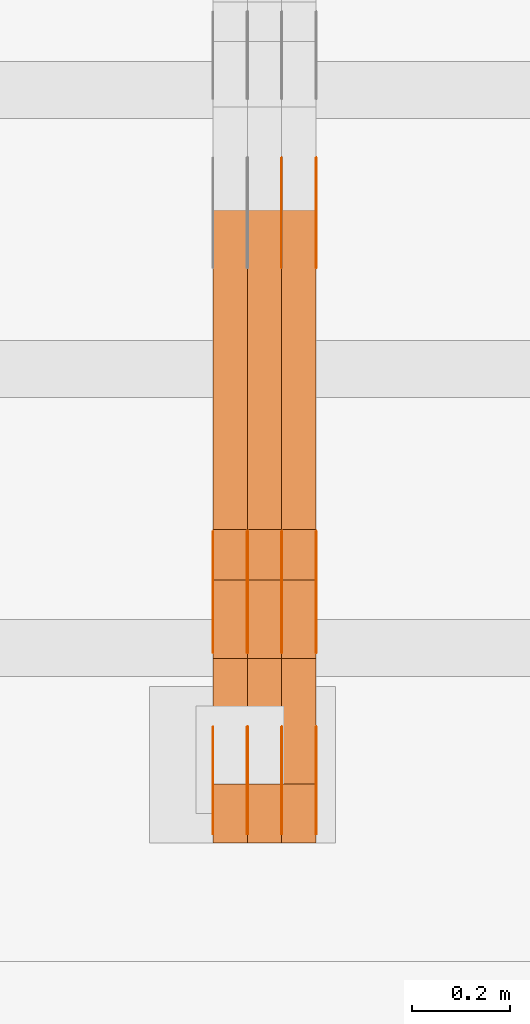
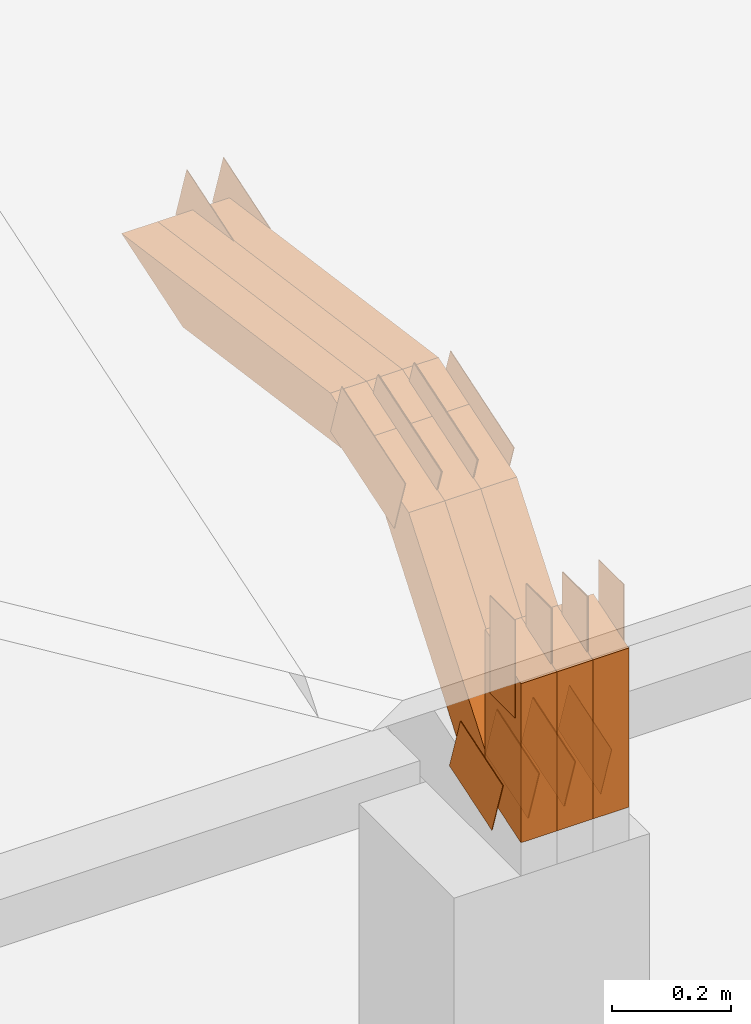
# One storey, part 108 of 385: 29 proxies.
"""IFC2X3 building model written with IfcOpenShell, lengths in millimetres."""

from ifc_helpers import new_model, entity, si_unit, converted_unit, derived_unit, direction, frame, frame_2d, origin, place, context, subcontext, project, spatial, polyline, rectangle, outline, extrude, source, transform, mapped, material, type_object, type_shapes, element, save


model = new_model("IFC2X3")

# Units and contexts
model_context = context("Model", 3, precision=0.01, world=origin(), true_north=direction((6.12303176911189e-17, 1.0)))
body_context = subcontext(model_context, "Body", "Model", "MODEL_VIEW")
ifc_project = project(units=[si_unit("LENGTHUNIT", "METRE", prefix="MILLI"), si_unit("AREAUNIT", "SQUARE_METRE"), si_unit("VOLUMEUNIT", "CUBIC_METRE"), converted_unit("PLANEANGLEUNIT", "DEGREE", entity("IfcRatioMeasure", 0.0174532925199433), si_unit("PLANEANGLEUNIT", "RADIAN"), dimensions=[0, 0, 0, 0, 0, 0, 0]), si_unit("MASSUNIT", "GRAM", prefix="KILO"), derived_unit("MASSDENSITYUNIT", [(si_unit("MASSUNIT", "GRAM", prefix="KILO"), 1), (si_unit("LENGTHUNIT", "METRE"), -3)]), si_unit("TIMEUNIT", "SECOND"), si_unit("FREQUENCYUNIT", "HERTZ"), si_unit("THERMODYNAMICTEMPERATUREUNIT", "DEGREE_CELSIUS"), derived_unit("THERMALTRANSMITTANCEUNIT", [(si_unit("MASSUNIT", "GRAM", prefix="KILO"), 1), (si_unit("THERMODYNAMICTEMPERATUREUNIT", "KELVIN"), -1), (si_unit("TIMEUNIT", "SECOND"), -3)]), derived_unit("VOLUMETRICFLOWRATEUNIT", [(si_unit("LENGTHUNIT", "METRE"), 3), (si_unit("TIMEUNIT", "SECOND"), -1)]), si_unit("ELECTRICCURRENTUNIT", "AMPERE"), si_unit("ELECTRICVOLTAGEUNIT", "VOLT"), si_unit("POWERUNIT", "WATT"), si_unit("FORCEUNIT", "NEWTON", prefix="KILO"), si_unit("ILLUMINANCEUNIT", "LUX"), si_unit("LUMINOUSFLUXUNIT", "LUMEN"), si_unit("LUMINOUSINTENSITYUNIT", "CANDELA"), derived_unit("USERDEFINED", [(si_unit("MASSUNIT", "GRAM", prefix="KILO"), -1), (si_unit("LENGTHUNIT", "METRE"), -2), (si_unit("TIMEUNIT", "SECOND"), 3), (si_unit("LUMINOUSFLUXUNIT", "LUMEN"), 1)]), derived_unit("LINEARVELOCITYUNIT", [(si_unit("LENGTHUNIT", "METRE"), 1), (si_unit("TIMEUNIT", "SECOND"), -1)]), si_unit("PRESSUREUNIT", "PASCAL"), derived_unit("USERDEFINED", [(si_unit("LENGTHUNIT", "METRE"), -2), (si_unit("MASSUNIT", "GRAM", prefix="KILO"), 1), (si_unit("TIMEUNIT", "SECOND"), -2)])], contexts=[model_context])

# Site, building, storey
site_placement = place(None, origin())
site = spatial("IfcSite", under=ifc_project, at=site_placement, CompositionType="ELEMENT")
building_placement = place(site_placement, origin())
building = spatial("IfcBuilding", under=site, at=building_placement, CompositionType="ELEMENT")
storey_placement = place(building_placement, origin())
storey = spatial("IfcBuildingStorey", under=building, at=storey_placement, Name="Default", CompositionType="ELEMENT", Elevation=0.0)

# Proxies
ifc_material_1 = material(Name="IfcSurfaceStyle #236732")
building_element_proxy_type_1 = type_object("IfcBuildingElementProxyType", PredefinedType="NOTDEFINED", material=ifc_material_1)
shared_shape_1 = source(origin(), body_context, "Body", "SweptSolid", [
    extrude(outline(polyline([(-74.999865408764, -60.0000379172698), (74.9998729365771, -60.0000379172698), (74.9998642299588, 60.0000379172698), (-74.9998717577719, 60.0000379172698), (-74.999865408764, -60.0000379172698)])), frame((75.0005044383734, 60.0001679035349, 0.0), z_axis=(0.0, 0.0, 1.0), x_axis=(-1.0, 0.0, 0.0)), (0.0, 0.0, 1.0), 1.3),
])
type_shapes(building_element_proxy_type_1, [shared_shape_1])
proxy_1_placement = place(building_placement, frame((18386.3, 2998.66143710397, 150.423871180894), z_axis=(-1.0, 0.0, 0.0), x_axis=(0.0, 0.951056516295124, 0.309016994375039)))
element("IfcBuildingElementProxy", 1, at=proxy_1_placement, inside=storey, type_object=building_element_proxy_type_1, material=ifc_material_1, context=body_context, shape_type="MappedRepresentation", body=[
    mapped(shared_shape_1, transform((0.0, 0.0, 0.0), scale=1.0)),
])
ifc_material_2 = material(Name="IfcSurfaceStyle #236675")
building_element_proxy_type_2 = type_object("IfcBuildingElementProxyType", PredefinedType="NOTDEFINED", material=ifc_material_2)
shared_shape_2 = source(origin(), body_context, "Body", "SweptSolid", [
    extrude(outline(polyline([(-74.999865408764, -60.0000379172698), (74.9998729365771, -60.0000379172698), (74.9998642299588, 60.0000379172698), (-74.9998717577719, 60.0000379172698), (-74.999865408764, -60.0000379172698)])), frame((75.0005044383734, 60.0001679035349, 0.0), z_axis=(0.0, 0.0, 1.0), x_axis=(-1.0, 0.0, 0.0)), (0.0, 0.0, 1.0), 1.3),
])
type_shapes(building_element_proxy_type_2, [shared_shape_2])
proxy_2_placement = place(building_placement, frame((18315.0, 2998.66143710397, 150.423871180894), z_axis=(-1.0, 0.0, 0.0), x_axis=(0.0, 0.951056516295124, 0.309016994375039)))
element("IfcBuildingElementProxy", 2, at=proxy_2_placement, inside=storey, type_object=building_element_proxy_type_2, material=ifc_material_2, context=body_context, shape_type="MappedRepresentation", body=[
    mapped(shared_shape_2, transform((0.0, 0.0, 0.0), scale=1.0)),
])
ifc_material_3 = material(Name="IfcSurfaceStyle #236618")
building_element_proxy_type_3 = type_object("IfcBuildingElementProxyType", PredefinedType="NOTDEFINED", material=ifc_material_3)
shared_shape_3 = source(origin(), body_context, "Body", "SweptSolid", [
    extrude(outline(polyline([(-74.999865408764, -60.0000379172698), (74.9998729365771, -60.0000379172698), (74.9998642299588, 60.0000379172698), (-74.9998717577719, 60.0000379172698), (-74.999865408764, -60.0000379172698)])), frame((75.0005044383734, 60.0001679035349, 0.0), z_axis=(0.0, 0.0, 1.0), x_axis=(-1.0, 0.0, 0.0)), (0.0, 0.0, 1.0), 1.3),
])
type_shapes(building_element_proxy_type_3, [shared_shape_3])
proxy_3_placement = place(building_placement, frame((18316.3, 2998.66143710397, 150.423871180894), z_axis=(-1.0, 0.0, 0.0), x_axis=(0.0, 0.951056516295124, 0.309016994375039)))
element("IfcBuildingElementProxy", 3, at=proxy_3_placement, inside=storey, type_object=building_element_proxy_type_3, material=ifc_material_3, context=body_context, shape_type="MappedRepresentation", body=[
    mapped(shared_shape_3, transform((0.0, 0.0, 0.0), scale=1.0)),
])
ifc_material_4 = material(Name="IfcSurfaceStyle #236561")
building_element_proxy_type_4 = type_object("IfcBuildingElementProxyType", PredefinedType="NOTDEFINED", material=ifc_material_4)
shared_shape_4 = source(origin(), body_context, "Body", "SweptSolid", [
    extrude(outline(polyline([(-74.999865408764, -60.0000379172698), (74.9998729365771, -60.0000379172698), (74.9998642299588, 60.0000379172698), (-74.9998717577719, 60.0000379172698), (-74.999865408764, -60.0000379172698)])), frame((75.0005044383734, 60.0001679035349, 0.0), z_axis=(0.0, 0.0, 1.0), x_axis=(-1.0, 0.0, 0.0)), (0.0, 0.0, 1.0), 1.29999999999999),
])
type_shapes(building_element_proxy_type_4, [shared_shape_4])
proxy_4_placement = place(building_placement, frame((18245.0, 2998.66143710397, 150.423871180894), z_axis=(-1.0, 0.0, 0.0), x_axis=(0.0, 0.951056516295124, 0.309016994375039)))
element("IfcBuildingElementProxy", 4, at=proxy_4_placement, inside=storey, type_object=building_element_proxy_type_4, material=ifc_material_4, context=body_context, shape_type="MappedRepresentation", body=[
    mapped(shared_shape_4, transform((0.0, 0.0, 0.0), scale=1.0)),
])
ifc_material_5 = material(Name="IfcSurfaceStyle #236504")
building_element_proxy_type_5 = type_object("IfcBuildingElementProxyType", PredefinedType="NOTDEFINED", material=ifc_material_5)
shared_shape_5 = source(origin(), body_context, "Body", "SweptSolid", [
    extrude(outline(polyline([(-74.999865408764, -60.0000379172698), (74.9998729365771, -60.0000379172698), (74.9998642299588, 60.0000379172698), (-74.9998717577719, 60.0000379172698), (-74.999865408764, -60.0000379172698)])), frame((75.0005044383734, 60.0001679035349, 0.0), z_axis=(0.0, 0.0, 1.0), x_axis=(-1.0, 0.0, 0.0)), (0.0, 0.0, 1.0), 1.29999999999999),
])
type_shapes(building_element_proxy_type_5, [shared_shape_5])
proxy_5_placement = place(building_placement, frame((18246.3, 2998.66143710397, 150.423871180894), z_axis=(-1.0, 0.0, 0.0), x_axis=(0.0, 0.951056516295124, 0.309016994375039)))
element("IfcBuildingElementProxy", 5, at=proxy_5_placement, inside=storey, type_object=building_element_proxy_type_5, material=ifc_material_5, context=body_context, shape_type="MappedRepresentation", body=[
    mapped(shared_shape_5, transform((0.0, 0.0, 0.0), scale=1.0)),
])
ifc_material_6 = material(Name="IfcSurfaceStyle #236447")
building_element_proxy_type_6 = type_object("IfcBuildingElementProxyType", PredefinedType="NOTDEFINED", material=ifc_material_6)
shared_shape_6 = source(origin(), body_context, "Body", "SweptSolid", [
    extrude(outline(polyline([(-74.999865408764, -60.0000379172698), (74.9998729365771, -60.0000379172698), (74.9998642299588, 60.0000379172698), (-74.9998717577719, 60.0000379172698), (-74.999865408764, -60.0000379172698)])), frame((75.0005044383734, 60.0001679035349, 0.0), z_axis=(0.0, 0.0, 1.0), x_axis=(-1.0, 0.0, 0.0)), (0.0, 0.0, 1.0), 1.29999999999999),
])
type_shapes(building_element_proxy_type_6, [shared_shape_6])
proxy_6_placement = place(building_placement, frame((18175.0, 2998.66143710397, 150.423871180894), z_axis=(-1.0, 0.0, 0.0), x_axis=(0.0, 0.951056516295124, 0.309016994375039)))
element("IfcBuildingElementProxy", 6, at=proxy_6_placement, inside=storey, type_object=building_element_proxy_type_6, material=ifc_material_6, context=body_context, shape_type="MappedRepresentation", body=[
    mapped(shared_shape_6, transform((0.0, 0.0, 0.0), scale=1.0)),
])
ifc_material_7 = material(Name="IfcSurfaceStyle #236390")
building_element_proxy_type_7 = type_object("IfcBuildingElementProxyType", PredefinedType="NOTDEFINED", material=ifc_material_7)
shared_shape_7 = source(origin(), body_context, "Body", "SweptSolid", [
    extrude(outline(polyline([(-99.9998204243802, -60.000067376167), (99.9998338462265, -60.000067376167), (99.9998204243802, 60.000067376167), (-99.9998338462265, 60.000067376167), (-99.9998204243802, -60.000067376167)])), frame((100.000602015329, 60.0001864986889, 0.0), z_axis=(0.0, 0.0, 1.0), x_axis=(-1.0, 0.0, 0.0)), (0.0, 0.0, 1.0), 1.3),
])
type_shapes(building_element_proxy_type_7, [shared_shape_7])
proxy_7_placement = place(building_placement, frame((18386.3, 4114.85465165112, 513.097031388771), z_axis=(-1.0, 0.0, 0.0), x_axis=(0.0, 0.951056516295124, 0.309016994375039)))
element("IfcBuildingElementProxy", 7, at=proxy_7_placement, inside=storey, type_object=building_element_proxy_type_7, material=ifc_material_7, context=body_context, shape_type="MappedRepresentation", body=[
    mapped(shared_shape_7, transform((0.0, 0.0, 0.0), scale=1.0)),
])
ifc_material_8 = material(Name="IfcSurfaceStyle #236333")
building_element_proxy_type_8 = type_object("IfcBuildingElementProxyType", PredefinedType="NOTDEFINED", material=ifc_material_8)
shared_shape_8 = source(origin(), body_context, "Body", "SweptSolid", [
    extrude(outline(polyline([(-99.9998204243802, -60.000067376167), (99.9998338462265, -60.000067376167), (99.9998204243802, 60.000067376167), (-99.9998338462265, 60.000067376167), (-99.9998204243802, -60.000067376167)])), frame((100.000602015329, 60.0001864986889, 0.0), z_axis=(0.0, 0.0, 1.0), x_axis=(-1.0, 0.0, 0.0)), (0.0, 0.0, 1.0), 1.3),
])
type_shapes(building_element_proxy_type_8, [shared_shape_8])
proxy_8_placement = place(building_placement, frame((18315.0, 4114.85465165112, 513.097031388771), z_axis=(-1.0, 0.0, 0.0), x_axis=(0.0, 0.951056516295124, 0.309016994375039)))
element("IfcBuildingElementProxy", 8, at=proxy_8_placement, inside=storey, type_object=building_element_proxy_type_8, material=ifc_material_8, context=body_context, shape_type="MappedRepresentation", body=[
    mapped(shared_shape_8, transform((0.0, 0.0, 0.0), scale=1.0)),
])
ifc_material_9 = material(Name="IfcSurfaceStyle #228182")
building_element_proxy_type_9 = type_object("IfcBuildingElementProxyType", PredefinedType="NOTDEFINED", material=ifc_material_9)
shared_shape_9 = source(origin(), body_context, "Body", "SweptSolid", [
    extrude(outline(polyline([(-112.500266735783, -59.9999130784581), (112.500275442392, -59.9999130784581), (112.500262020557, 59.9999130784582), (-112.500270727166, 59.9999130784581), (-112.500266735783, -59.9999130784581)])), frame((112.500275442392, 60.0001020984692, 0.0), z_axis=(0.0, 0.0, 1.0), x_axis=(-1.0, 0.0, 0.0)), (0.0, 0.0, 1.0), 1.3),
])
type_shapes(building_element_proxy_type_9, [shared_shape_9])
proxy_9_placement = place(building_placement, frame((18386.3, 3327.32420598508, 571.284602786019), z_axis=(-1.0, 0.0, 0.0), x_axis=(0.0, 0.951056516295154, 0.309016994374948)))
element("IfcBuildingElementProxy", 9, at=proxy_9_placement, inside=storey, type_object=building_element_proxy_type_9, material=ifc_material_9, context=body_context, shape_type="MappedRepresentation", body=[
    mapped(shared_shape_9, transform((0.0, 0.0, 0.0), scale=1.0)),
])
ifc_material_10 = material(Name="IfcSurfaceStyle #228125")
building_element_proxy_type_10 = type_object("IfcBuildingElementProxyType", PredefinedType="NOTDEFINED", material=ifc_material_10)
shared_shape_10 = source(origin(), body_context, "Body", "SweptSolid", [
    extrude(outline(polyline([(-112.500266735783, -59.9999130784581), (112.500275442392, -59.9999130784581), (112.500262020557, 59.9999130784582), (-112.500270727166, 59.9999130784581), (-112.500266735783, -59.9999130784581)])), frame((112.500275442392, 60.0001020984692, 0.0), z_axis=(0.0, 0.0, 1.0), x_axis=(-1.0, 0.0, 0.0)), (0.0, 0.0, 1.0), 1.3),
])
type_shapes(building_element_proxy_type_10, [shared_shape_10])
proxy_10_placement = place(building_placement, frame((18315.0, 3327.32420598508, 571.284602786019), z_axis=(-1.0, 0.0, 0.0), x_axis=(0.0, 0.951056516295154, 0.309016994374948)))
element("IfcBuildingElementProxy", 10, at=proxy_10_placement, inside=storey, type_object=building_element_proxy_type_10, material=ifc_material_10, context=body_context, shape_type="MappedRepresentation", body=[
    mapped(shared_shape_10, transform((0.0, 0.0, 0.0), scale=1.0)),
])
ifc_material_11 = material(Name="IfcSurfaceStyle #228068")
building_element_proxy_type_11 = type_object("IfcBuildingElementProxyType", PredefinedType="NOTDEFINED", material=ifc_material_11)
shared_shape_11 = source(origin(), body_context, "Body", "SweptSolid", [
    extrude(outline(polyline([(-112.500266735783, -59.9999130784581), (112.500275442392, -59.9999130784581), (112.500262020557, 59.9999130784582), (-112.500270727166, 59.9999130784581), (-112.500266735783, -59.9999130784581)])), frame((112.500275442392, 60.0001020984692, 0.0), z_axis=(0.0, 0.0, 1.0), x_axis=(-1.0, 0.0, 0.0)), (0.0, 0.0, 1.0), 1.3),
])
type_shapes(building_element_proxy_type_11, [shared_shape_11])
proxy_11_placement = place(building_placement, frame((18316.3, 3327.32420598508, 571.284602786019), z_axis=(-1.0, 0.0, 0.0), x_axis=(0.0, 0.951056516295154, 0.309016994374948)))
element("IfcBuildingElementProxy", 11, at=proxy_11_placement, inside=storey, type_object=building_element_proxy_type_11, material=ifc_material_11, context=body_context, shape_type="MappedRepresentation", body=[
    mapped(shared_shape_11, transform((0.0, 0.0, 0.0), scale=1.0)),
])
ifc_material_12 = material(Name="IfcSurfaceStyle #228011")
building_element_proxy_type_12 = type_object("IfcBuildingElementProxyType", PredefinedType="NOTDEFINED", material=ifc_material_12)
shared_shape_12 = source(origin(), body_context, "Body", "SweptSolid", [
    extrude(outline(polyline([(-112.500266735783, -59.9999130784581), (112.500275442392, -59.9999130784581), (112.500262020557, 59.9999130784582), (-112.500270727166, 59.9999130784581), (-112.500266735783, -59.9999130784581)])), frame((112.500275442392, 60.0001020984692, 0.0), z_axis=(0.0, 0.0, 1.0), x_axis=(-1.0, 0.0, 0.0)), (0.0, 0.0, 1.0), 1.29999999999998),
])
type_shapes(building_element_proxy_type_12, [shared_shape_12])
proxy_12_placement = place(building_placement, frame((18245.0, 3327.32420598508, 571.284602786019), z_axis=(-1.0, 0.0, 0.0), x_axis=(0.0, 0.951056516295154, 0.309016994374948)))
element("IfcBuildingElementProxy", 12, at=proxy_12_placement, inside=storey, type_object=building_element_proxy_type_12, material=ifc_material_12, context=body_context, shape_type="MappedRepresentation", body=[
    mapped(shared_shape_12, transform((0.0, 0.0, 0.0), scale=1.0)),
])
ifc_material_13 = material(Name="IfcSurfaceStyle #227954")
building_element_proxy_type_13 = type_object("IfcBuildingElementProxyType", PredefinedType="NOTDEFINED", material=ifc_material_13)
shared_shape_13 = source(origin(), body_context, "Body", "SweptSolid", [
    extrude(outline(polyline([(-112.500266735783, -59.9999130784581), (112.500275442392, -59.9999130784581), (112.500262020557, 59.9999130784582), (-112.500270727166, 59.9999130784581), (-112.500266735783, -59.9999130784581)])), frame((112.500275442392, 60.0001020984692, 0.0), z_axis=(0.0, 0.0, 1.0), x_axis=(-1.0, 0.0, 0.0)), (0.0, 0.0, 1.0), 1.29999999999998),
])
type_shapes(building_element_proxy_type_13, [shared_shape_13])
proxy_13_placement = place(building_placement, frame((18246.3, 3327.32420598508, 571.284602786019), z_axis=(-1.0, 0.0, 0.0), x_axis=(0.0, 0.951056516295154, 0.309016994374948)))
element("IfcBuildingElementProxy", 13, at=proxy_13_placement, inside=storey, type_object=building_element_proxy_type_13, material=ifc_material_13, context=body_context, shape_type="MappedRepresentation", body=[
    mapped(shared_shape_13, transform((0.0, 0.0, 0.0), scale=1.0)),
])
ifc_material_14 = material(Name="IfcSurfaceStyle #227897")
building_element_proxy_type_14 = type_object("IfcBuildingElementProxyType", PredefinedType="NOTDEFINED", material=ifc_material_14)
shared_shape_14 = source(origin(), body_context, "Body", "SweptSolid", [
    extrude(outline(polyline([(-112.500266735783, -59.9999130784581), (112.500275442392, -59.9999130784581), (112.500262020557, 59.9999130784582), (-112.500270727166, 59.9999130784581), (-112.500266735783, -59.9999130784581)])), frame((112.500275442392, 60.0001020984692, 0.0), z_axis=(0.0, 0.0, 1.0), x_axis=(-1.0, 0.0, 0.0)), (0.0, 0.0, 1.0), 1.29999999999999),
])
type_shapes(building_element_proxy_type_14, [shared_shape_14])
proxy_14_placement = place(building_placement, frame((18175.0, 3327.32420598508, 571.284602786019), z_axis=(-1.0, 0.0, 0.0), x_axis=(0.0, 0.951056516295154, 0.309016994374948)))
element("IfcBuildingElementProxy", 14, at=proxy_14_placement, inside=storey, type_object=building_element_proxy_type_14, material=ifc_material_14, context=body_context, shape_type="MappedRepresentation", body=[
    mapped(shared_shape_14, transform((0.0, 0.0, 0.0), scale=1.0)),
])
ifc_material_15 = material(Name="IfcSurfaceStyle #227156")
building_element_proxy_type_15 = type_object("IfcBuildingElementProxyType", PredefinedType="NOTDEFINED", material=ifc_material_15)
shared_shape_15 = source(origin(), body_context, "Body", "SweptSolid", [
    extrude(rectangle(XDim=199.999969482422, YDim=84.0, at=frame_2d((1.4210854715202e-14, 0.0), x_axis=(1.0, 0.0))), frame((100.000010815955, 42.0, 0.0), z_axis=(0.0, 0.0, 1.0), x_axis=(-1.0, 0.0, 0.0)), (0.0, 0.0, 1.0), 1.3),
])
type_shapes(building_element_proxy_type_15, [shared_shape_15])
proxy_15_placement = place(building_placement, frame((18386.3, 3042.0, 514.460048047401), z_axis=(-1.0, 0.0, 0.0), x_axis=(0.0, 0.0, -1.0)))
element("IfcBuildingElementProxy", 15, at=proxy_15_placement, inside=storey, type_object=building_element_proxy_type_15, material=ifc_material_15, context=body_context, shape_type="MappedRepresentation", body=[
    mapped(shared_shape_15, transform((0.0, 0.0, 0.0), scale=1.0)),
])
ifc_material_16 = material(Name="IfcSurfaceStyle #227099")
building_element_proxy_type_16 = type_object("IfcBuildingElementProxyType", PredefinedType="NOTDEFINED", material=ifc_material_16)
shared_shape_16 = source(origin(), body_context, "Body", "SweptSolid", [
    extrude(rectangle(XDim=199.999969482422, YDim=84.0, at=frame_2d((1.4210854715202e-14, 0.0), x_axis=(1.0, 0.0))), frame((100.000010815955, 42.0, 0.0), z_axis=(0.0, 0.0, 1.0), x_axis=(-1.0, 0.0, 0.0)), (0.0, 0.0, 1.0), 1.3),
])
type_shapes(building_element_proxy_type_16, [shared_shape_16])
proxy_16_placement = place(building_placement, frame((18315.0, 3042.0, 514.460048047401), z_axis=(-1.0, 0.0, 0.0), x_axis=(0.0, 0.0, -1.0)))
element("IfcBuildingElementProxy", 16, at=proxy_16_placement, inside=storey, type_object=building_element_proxy_type_16, material=ifc_material_16, context=body_context, shape_type="MappedRepresentation", body=[
    mapped(shared_shape_16, transform((0.0, 0.0, 0.0), scale=1.0)),
])
ifc_material_17 = material(Name="IfcSurfaceStyle #227042")
building_element_proxy_type_17 = type_object("IfcBuildingElementProxyType", PredefinedType="NOTDEFINED", material=ifc_material_17)
shared_shape_17 = source(origin(), body_context, "Body", "SweptSolid", [
    extrude(rectangle(XDim=199.999969482422, YDim=84.0, at=frame_2d((1.4210854715202e-14, 0.0), x_axis=(1.0, 0.0))), frame((100.000010815955, 42.0, 0.0), z_axis=(0.0, 0.0, 1.0), x_axis=(-1.0, 0.0, 0.0)), (0.0, 0.0, 1.0), 1.3),
])
type_shapes(building_element_proxy_type_17, [shared_shape_17])
proxy_17_placement = place(building_placement, frame((18316.3, 3042.0, 514.460048047401), z_axis=(-1.0, 0.0, 0.0), x_axis=(0.0, 0.0, -1.0)))
element("IfcBuildingElementProxy", 17, at=proxy_17_placement, inside=storey, type_object=building_element_proxy_type_17, material=ifc_material_17, context=body_context, shape_type="MappedRepresentation", body=[
    mapped(shared_shape_17, transform((0.0, 0.0, 0.0), scale=1.0)),
])
ifc_material_18 = material(Name="IfcSurfaceStyle #226985")
building_element_proxy_type_18 = type_object("IfcBuildingElementProxyType", PredefinedType="NOTDEFINED", material=ifc_material_18)
shared_shape_18 = source(origin(), body_context, "Body", "SweptSolid", [
    extrude(rectangle(XDim=199.999969482422, YDim=84.0, at=frame_2d((1.4210854715202e-14, 0.0), x_axis=(1.0, 0.0))), frame((100.000010815955, 42.0, 0.0), z_axis=(0.0, 0.0, 1.0), x_axis=(-1.0, 0.0, 0.0)), (0.0, 0.0, 1.0), 1.29999999999998),
])
type_shapes(building_element_proxy_type_18, [shared_shape_18])
proxy_18_placement = place(building_placement, frame((18245.0, 3042.0, 514.460048047401), z_axis=(-1.0, 0.0, 0.0), x_axis=(0.0, 0.0, -1.0)))
element("IfcBuildingElementProxy", 18, at=proxy_18_placement, inside=storey, type_object=building_element_proxy_type_18, material=ifc_material_18, context=body_context, shape_type="MappedRepresentation", body=[
    mapped(shared_shape_18, transform((0.0, 0.0, 0.0), scale=1.0)),
])
ifc_material_19 = material(Name="IfcSurfaceStyle #226928")
building_element_proxy_type_19 = type_object("IfcBuildingElementProxyType", PredefinedType="NOTDEFINED", material=ifc_material_19)
shared_shape_19 = source(origin(), body_context, "Body", "SweptSolid", [
    extrude(rectangle(XDim=199.999969482422, YDim=84.0, at=frame_2d((1.4210854715202e-14, 0.0), x_axis=(1.0, 0.0))), frame((100.000010815955, 42.0, 0.0), z_axis=(0.0, 0.0, 1.0), x_axis=(-1.0, 0.0, 0.0)), (0.0, 0.0, 1.0), 1.29999999999998),
])
type_shapes(building_element_proxy_type_19, [shared_shape_19])
proxy_19_placement = place(building_placement, frame((18246.3, 3042.0, 514.460048047401), z_axis=(-1.0, 0.0, 0.0), x_axis=(0.0, 0.0, -1.0)))
element("IfcBuildingElementProxy", 19, at=proxy_19_placement, inside=storey, type_object=building_element_proxy_type_19, material=ifc_material_19, context=body_context, shape_type="MappedRepresentation", body=[
    mapped(shared_shape_19, transform((0.0, 0.0, 0.0), scale=1.0)),
])
ifc_material_20 = material(Name="IfcSurfaceStyle #226871")
building_element_proxy_type_20 = type_object("IfcBuildingElementProxyType", PredefinedType="NOTDEFINED", material=ifc_material_20)
shared_shape_20 = source(origin(), body_context, "Body", "SweptSolid", [
    extrude(rectangle(XDim=199.999969482422, YDim=84.0, at=frame_2d((1.4210854715202e-14, 0.0), x_axis=(1.0, 0.0))), frame((100.000010815955, 42.0, 0.0), z_axis=(0.0, 0.0, 1.0), x_axis=(-1.0, 0.0, 0.0)), (0.0, 0.0, 1.0), 1.29999999999999),
])
type_shapes(building_element_proxy_type_20, [shared_shape_20])
proxy_20_placement = place(building_placement, frame((18175.0, 3042.0, 514.460048047401), z_axis=(-1.0, 0.0, 0.0), x_axis=(0.0, 0.0, -1.0)))
element("IfcBuildingElementProxy", 20, at=proxy_20_placement, inside=storey, type_object=building_element_proxy_type_20, material=ifc_material_20, context=body_context, shape_type="MappedRepresentation", body=[
    mapped(shared_shape_20, transform((0.0, 0.0, 0.0), scale=1.0)),
])
ifc_material_21 = material(Name="IfcSurfaceStyle #215888")
building_element_proxy_type_21 = type_object("IfcBuildingElementProxyType", Name="T1-W3 215886", PredefinedType="NOTDEFINED", material=ifc_material_21)
shared_shape_21 = source(origin(), body_context, "Body", "SweptSolid", [
    extrude(outline(polyline([(-314.232579911788, -47.5000200125938), (325.164873061766, -47.5000200125938), (297.999869081008, 6.48085173424295e-05), (200.434027234171, 47.4999876083351), (-509.366189465157, 47.4999876083352), (-314.232579911788, -47.5000200125938)])), frame((325.164873061766, 47.5001564752191, 0.0), z_axis=(0.0, 0.0, 1.0), x_axis=(-1.0, 0.0, 0.0)), (0.0, 0.0, 1.0), 70.0),
])
type_shapes(building_element_proxy_type_21, [shared_shape_21])
proxy_21_placement = place(building_placement, frame((18385.0, 3457.43747924875, 620.49890325051), z_axis=(-1.0, 0.0, 0.0), x_axis=(0.0, 0.990367219823621, -0.138465771578512)))
element("IfcBuildingElementProxy", 21, at=proxy_21_placement, inside=storey, type_object=building_element_proxy_type_21, material=ifc_material_21, Name="T1-W3", context=body_context, shape_type="MappedRepresentation", body=[
    mapped(shared_shape_21, transform((0.0, 0.0, 0.0), scale=1.0)),
])
ifc_material_22 = material(Name="IfcSurfaceStyle #215822")
building_element_proxy_type_22 = type_object("IfcBuildingElementProxyType", Name="T1-W3 215820", PredefinedType="NOTDEFINED", material=ifc_material_22)
shared_shape_22 = source(origin(), body_context, "Body", "SweptSolid", [
    extrude(outline(polyline([(-314.232579911788, -47.5000200125938), (325.164873061766, -47.5000200125938), (297.999869081008, 6.48085173424295e-05), (200.434027234171, 47.4999876083351), (-509.366189465157, 47.4999876083352), (-314.232579911788, -47.5000200125938)])), frame((325.164873061766, 47.5001564752191, 0.0), z_axis=(0.0, 0.0, 1.0), x_axis=(-1.0, 0.0, 0.0)), (0.0, 0.0, 1.0), 70.0),
])
type_shapes(building_element_proxy_type_22, [shared_shape_22])
proxy_22_placement = place(building_placement, frame((18315.0, 3457.43747924875, 620.49890325051), z_axis=(-1.0, 0.0, 0.0), x_axis=(0.0, 0.990367219823621, -0.138465771578512)))
element("IfcBuildingElementProxy", 22, at=proxy_22_placement, inside=storey, type_object=building_element_proxy_type_22, material=ifc_material_22, Name="T1-W3", context=body_context, shape_type="MappedRepresentation", body=[
    mapped(shared_shape_22, transform((0.0, 0.0, 0.0), scale=1.0)),
])
ifc_material_23 = material(Name="IfcSurfaceStyle #215756")
building_element_proxy_type_23 = type_object("IfcBuildingElementProxyType", Name="T1-W3 215754", PredefinedType="NOTDEFINED", material=ifc_material_23)
shared_shape_23 = source(origin(), body_context, "Body", "SweptSolid", [
    extrude(outline(polyline([(-314.232579911788, -47.5000200125938), (325.164873061766, -47.5000200125938), (297.999869081008, 6.48085173424295e-05), (200.434027234171, 47.4999876083351), (-509.366189465157, 47.4999876083352), (-314.232579911788, -47.5000200125938)])), frame((325.164873061766, 47.5001564752191, 0.0), z_axis=(0.0, 0.0, 1.0), x_axis=(-1.0, 0.0, 0.0)), (0.0, 0.0, 1.0), 70.0),
])
type_shapes(building_element_proxy_type_23, [shared_shape_23])
proxy_23_placement = place(building_placement, frame((18245.0, 3457.43747924875, 620.49890325051), z_axis=(-1.0, 0.0, 0.0), x_axis=(0.0, 0.990367219823621, -0.138465771578512)))
element("IfcBuildingElementProxy", 23, at=proxy_23_placement, inside=storey, type_object=building_element_proxy_type_23, material=ifc_material_23, Name="T1-W3", context=body_context, shape_type="MappedRepresentation", body=[
    mapped(shared_shape_23, transform((0.0, 0.0, 0.0), scale=1.0)),
])
ifc_material_24 = material(Name="IfcSurfaceStyle #215492")
building_element_proxy_type_24 = type_object("IfcBuildingElementProxyType", Name="T1-W14 215490", PredefinedType="NOTDEFINED", material=ifc_material_24)
shared_shape_24 = source(origin(), body_context, "Body", "SweptSolid", [
    extrude(outline(polyline([(-374.484689776928, -47.499919737532), (177.199556189275, -47.499919737532), (246.893257937645, -5.36774925340877e-05), (185.487930694801, 47.4999465762783), (-235.096055044793, 47.4999465762784), (-374.484689776928, -47.499919737532)])), frame((246.893257937645, 47.5000959779252, 0.0), z_axis=(0.0, 0.0, 1.0), x_axis=(-1.0, 0.0, 0.0)), (0.0, 0.0, 1.0), 70.0),
])
type_shapes(building_element_proxy_type_24, [shared_shape_24])
proxy_24_placement = place(building_placement, frame((18385.0, 3022.42877773024, 136.329406512195), z_axis=(-1.0, 0.0, 0.0), x_axis=(0.0, 0.611854146609475, 0.790970608352037)))
element("IfcBuildingElementProxy", 24, at=proxy_24_placement, inside=storey, type_object=building_element_proxy_type_24, material=ifc_material_24, Name="T1-W14", context=body_context, shape_type="MappedRepresentation", body=[
    mapped(shared_shape_24, transform((0.0, 0.0, 0.0), scale=1.0)),
])
ifc_material_25 = material(Name="IfcSurfaceStyle #215426")
building_element_proxy_type_25 = type_object("IfcBuildingElementProxyType", Name="T1-W14 215424", PredefinedType="NOTDEFINED", material=ifc_material_25)
shared_shape_25 = source(origin(), body_context, "Body", "SweptSolid", [
    extrude(outline(polyline([(-374.484689776928, -47.499919737532), (177.199556189275, -47.499919737532), (246.893257937645, -5.36774925340877e-05), (185.487930694801, 47.4999465762783), (-235.096055044793, 47.4999465762784), (-374.484689776928, -47.499919737532)])), frame((246.893257937645, 47.5000959779252, 0.0), z_axis=(0.0, 0.0, 1.0), x_axis=(-1.0, 0.0, 0.0)), (0.0, 0.0, 1.0), 70.0),
])
type_shapes(building_element_proxy_type_25, [shared_shape_25])
proxy_25_placement = place(building_placement, frame((18315.0, 3022.42877773024, 136.329406512195), z_axis=(-1.0, 0.0, 0.0), x_axis=(0.0, 0.611854146609475, 0.790970608352037)))
element("IfcBuildingElementProxy", 25, at=proxy_25_placement, inside=storey, type_object=building_element_proxy_type_25, material=ifc_material_25, Name="T1-W14", context=body_context, shape_type="MappedRepresentation", body=[
    mapped(shared_shape_25, transform((0.0, 0.0, 0.0), scale=1.0)),
])
ifc_material_26 = material(Name="IfcSurfaceStyle #215360")
building_element_proxy_type_26 = type_object("IfcBuildingElementProxyType", Name="T1-W14 215358", PredefinedType="NOTDEFINED", material=ifc_material_26)
shared_shape_26 = source(origin(), body_context, "Body", "SweptSolid", [
    extrude(outline(polyline([(-374.484689776928, -47.499919737532), (177.199556189275, -47.499919737532), (246.893257937645, -5.36774925340877e-05), (185.487930694801, 47.4999465762783), (-235.096055044793, 47.4999465762784), (-374.484689776928, -47.499919737532)])), frame((246.893257937645, 47.5000959779252, 0.0), z_axis=(0.0, 0.0, 1.0), x_axis=(-1.0, 0.0, 0.0)), (0.0, 0.0, 1.0), 70.0),
])
type_shapes(building_element_proxy_type_26, [shared_shape_26])
proxy_26_placement = place(building_placement, frame((18245.0, 3022.42877773024, 136.329406512195), z_axis=(-1.0, 0.0, 0.0), x_axis=(0.0, 0.611854146609475, 0.790970608352037)))
element("IfcBuildingElementProxy", 26, at=proxy_26_placement, inside=storey, type_object=building_element_proxy_type_26, material=ifc_material_26, Name="T1-W14", context=body_context, shape_type="MappedRepresentation", body=[
    mapped(shared_shape_26, transform((0.0, 0.0, 0.0), scale=1.0)),
])
ifc_material_27 = material(Name="IfcSurfaceStyle #215294")
building_element_proxy_type_27 = type_object("IfcBuildingElementProxyType", Name="T1-E3 215292", PredefinedType="NOTDEFINED", material=ifc_material_27)
shared_shape_27 = source(origin(), body_context, "Body", "SweptSolid", [
    extrude(outline(polyline([(-182.839673995971, -60.0), (143.849313735962, -60.0), (182.839677810669, 60.0), (-143.84931755066, 60.0), (-182.839673995971, -60.0)])), frame((182.839677810669, 60.0, 0.0), z_axis=(0.0, 0.0, 1.0), x_axis=(-1.0, 0.0, 0.0)), (0.0, 0.0, 1.0), 70.0),
])
type_shapes(building_element_proxy_type_27, [shared_shape_27])
proxy_27_placement = place(building_placement, frame((18385.0, 2940.0, 68.27587890625), z_axis=(-1.0, 0.0, 0.0), x_axis=(0.0, 0.0, 1.0)))
element("IfcBuildingElementProxy", 27, at=proxy_27_placement, inside=storey, type_object=building_element_proxy_type_27, material=ifc_material_27, Name="T1-E3", context=body_context, shape_type="MappedRepresentation", body=[
    mapped(shared_shape_27, transform((0.0, 0.0, 0.0), scale=1.0)),
])
ifc_material_28 = material(Name="IfcSurfaceStyle #215237")
building_element_proxy_type_28 = type_object("IfcBuildingElementProxyType", Name="T1-E3 215235", PredefinedType="NOTDEFINED", material=ifc_material_28)
shared_shape_28 = source(origin(), body_context, "Body", "SweptSolid", [
    extrude(outline(polyline([(-182.839673995971, -60.0), (143.849313735962, -60.0), (182.839677810669, 60.0), (-143.84931755066, 60.0), (-182.839673995971, -60.0)])), frame((182.839677810669, 60.0, 0.0), z_axis=(0.0, 0.0, 1.0), x_axis=(-1.0, 0.0, 0.0)), (0.0, 0.0, 1.0), 70.0),
])
type_shapes(building_element_proxy_type_28, [shared_shape_28])
proxy_28_placement = place(building_placement, frame((18315.0, 2940.0, 68.27587890625), z_axis=(-1.0, 0.0, 0.0), x_axis=(0.0, 0.0, 1.0)))
element("IfcBuildingElementProxy", 28, at=proxy_28_placement, inside=storey, type_object=building_element_proxy_type_28, material=ifc_material_28, Name="T1-E3", context=body_context, shape_type="MappedRepresentation", body=[
    mapped(shared_shape_28, transform((0.0, 0.0, 0.0), scale=1.0)),
])
ifc_material_29 = material(Name="IfcSurfaceStyle #215180")
building_element_proxy_type_29 = type_object("IfcBuildingElementProxyType", Name="T1-E3 215178", PredefinedType="NOTDEFINED", material=ifc_material_29)
shared_shape_29 = source(origin(), body_context, "Body", "SweptSolid", [
    extrude(outline(polyline([(-182.839673995971, -60.0), (143.849313735962, -60.0), (182.839677810669, 60.0), (-143.84931755066, 60.0), (-182.839673995971, -60.0)])), frame((182.839677810669, 60.0, 0.0), z_axis=(0.0, 0.0, 1.0), x_axis=(-1.0, 0.0, 0.0)), (0.0, 0.0, 1.0), 70.0),
])
type_shapes(building_element_proxy_type_29, [shared_shape_29])
proxy_29_placement = place(building_placement, frame((18245.0, 2940.0, 68.27587890625), z_axis=(-1.0, 0.0, 0.0), x_axis=(0.0, 0.0, 1.0)))
element("IfcBuildingElementProxy", 29, at=proxy_29_placement, inside=storey, type_object=building_element_proxy_type_29, material=ifc_material_29, Name="T1-E3", context=body_context, shape_type="MappedRepresentation", body=[
    mapped(shared_shape_29, transform((0.0, 0.0, 0.0), scale=1.0)),
])

save(model, "model.ifc")
